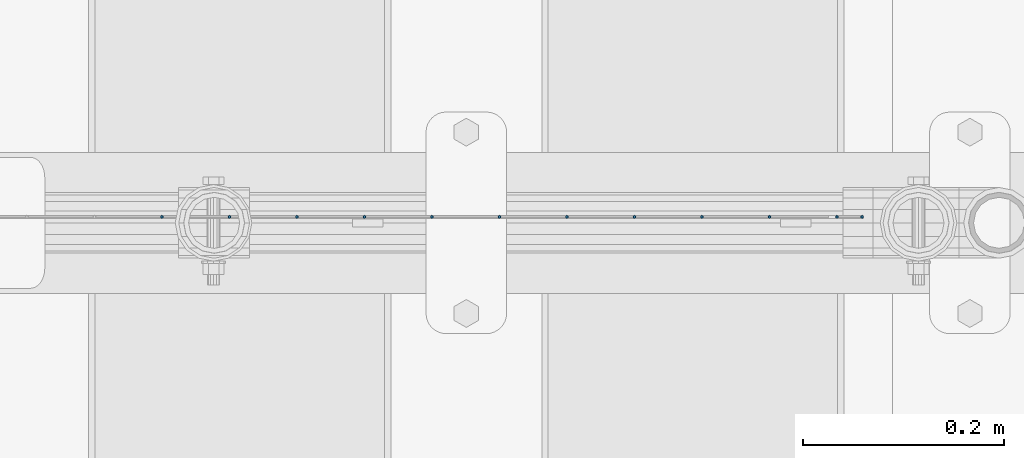
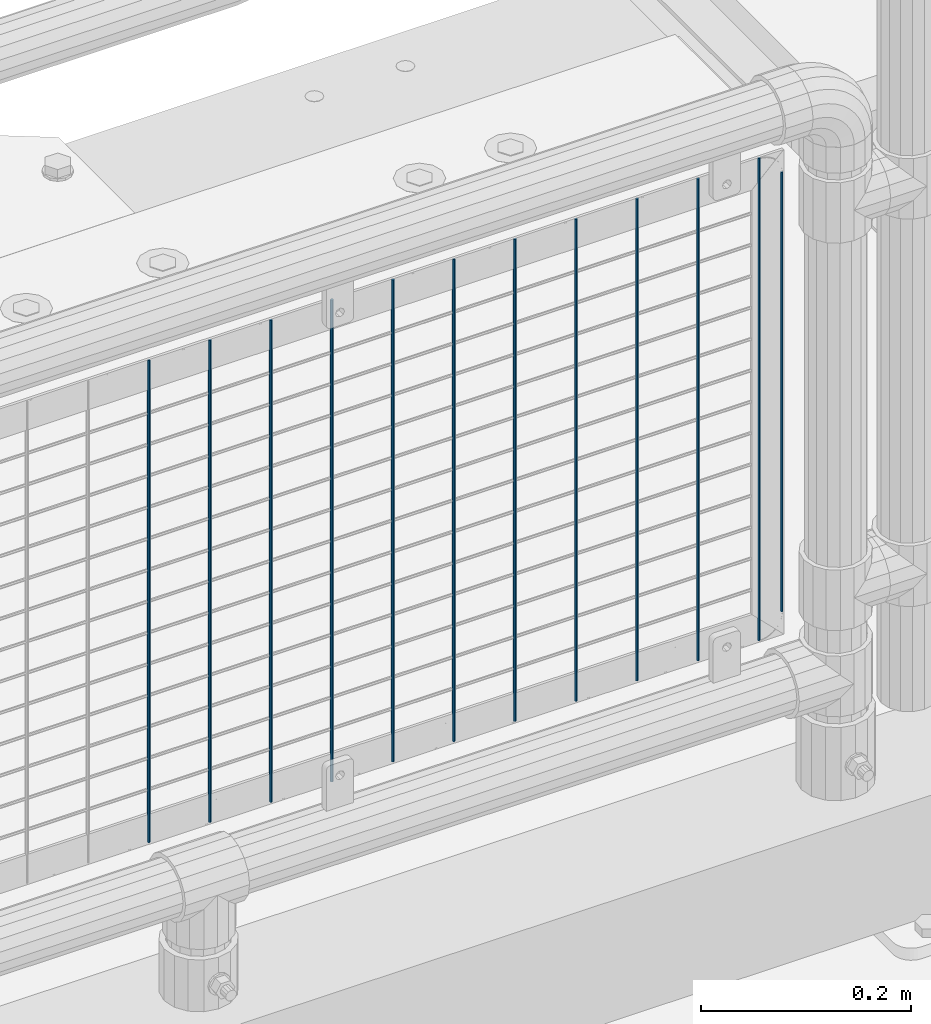
# One storey, part 112 of 270: 12 columns.
"""IFC2X3 building model written with IfcOpenShell, lengths in millimetres."""

from ifc_helpers import new_model, si_unit, frame, origin_with_axes, place, context, subcontext, project, spatial, faceted_brep, material, type_object, element, save


model = new_model("IFC2X3")

# Units and contexts
model_context = context("Model", 3, precision=1e-05, world=origin_with_axes())
body_context = subcontext(model_context, "Body", "Model", "MODEL_VIEW")
ifc_project = project(units=[si_unit("LENGTHUNIT", "METRE", prefix="MILLI"), si_unit("AREAUNIT", "SQUARE_METRE"), si_unit("VOLUMEUNIT", "CUBIC_METRE"), si_unit("MASSUNIT", "GRAM", prefix="KILO"), si_unit("TIMEUNIT", "SECOND"), si_unit("PLANEANGLEUNIT", "RADIAN"), si_unit("SOLIDANGLEUNIT", "STERADIAN"), si_unit("THERMODYNAMICTEMPERATUREUNIT", "DEGREE_CELSIUS"), si_unit("LUMINOUSINTENSITYUNIT", "LUMEN")], contexts=[model_context])

# Site, building, storey
site_placement = place(None, origin_with_axes())
site = spatial("IfcSite", under=ifc_project, at=site_placement, CompositionType="ELEMENT")
building_placement = place(site_placement, origin_with_axes())
building = spatial("IfcBuilding", under=site, at=building_placement, Name="Standard", CompositionType="ELEMENT")
storey_placement = place(building_placement, origin_with_axes())
storey = spatial("IfcBuildingStorey", under=building, at=storey_placement, Name="Undefined", CompositionType="ELEMENT", Elevation=0.0)

# Columns
ifc_material = material(Name="Misc_Undefined")
column_type = type_object("IfcColumnType", Name="D3", PredefinedType="NOTDEFINED")
for number, where, z_axis, x_axis in (
    (1, (19713.0020000001, -16329.5002158991, 353.02), (-1.0, 0.0, 0.0), (0.0, 0.0, 1.0)),
    (2, (19645.9740000001, -16329.5002016903, 353.02), (-1.0, 0.0, 0.0), (0.0, 0.0, 1.0)),
    (3, (19578.9460000001, -16329.5001874815, 353.02), (-1.0, 0.0, 0.0), (0.0, 0.0, 1.0)),
    (4, (19511.9180000001, -16329.5001732727, 353.02), (-1.0, 0.0, 0.0), (0.0, 0.0, 1.0)),
    (5, (19444.8900000001, -16329.5001590638, 353.02), (-1.0, 0.0, 0.0), (0.0, 0.0, 1.0)),
    (6, (19377.8620000001, -16329.500144855, 353.02), (-1.0, 0.0, 0.0), (0.0, 0.0, 1.0)),
    (7, (19310.8340000001, -16329.5001306462, 353.02), (-1.0, 0.0, 0.0), (0.0, 0.0, 1.0)),
    (8, (19109.7500000001, -16329.5000880198, 353.02), (-1.0, 0.0, 0.0), (0.0, 0.0, 1.0)),
    (9, (19042.7220000001, -16329.500073811, 353.02), (-1.0, 0.0, 0.0), (0.0, 0.0, 1.0)),
    (10, (19176.7780000001, -16329.5001022286, 353.02), (-1.0, 0.0, 0.0), (0.0, 0.0, 1.0)),
    (11, (19243.8060000001, -16329.5001164374, 353.02), (-1.0, 0.0, 0.0), (0.0, 0.0, 1.0)),
):
    element("IfcColumn", number, at=place(storey_placement, frame(where, z_axis=z_axis, x_axis=x_axis)), inside=storey, type_object=column_type, material=ifc_material, ObjectType="D3", context=body_context, shape_type="Brep", body=[
        faceted_brep([(0.0, -1.5, 0.0), (0.0, -0.75, -1.29903810567669), (560.0, -0.75, -1.29903810567703), (560.0, -1.5, 0.0), (0.0, 0.75, -1.29903810567669), (560.0, 0.75, -1.29903810567703), (0.0, 1.5, 0.0), (560.0, 1.5, 0.0), (0.0, 0.75, 1.29903810567669), (560.0, 0.75, 1.29903810567703), (0.0, -0.75, 1.29903810567669), (560.0, -0.75, 1.29903810567703)], [[[0, 1, 2, 3]], [[1, 4, 5, 2]], [[4, 6, 7, 5]], [[6, 8, 9, 7]], [[8, 10, 11, 9]], [[10, 0, 3, 11]], [[5, 7, 9, 11, 3, 2]], [[10, 8, 6, 4, 1, 0]]]),
    ])
column_placement = place(storey_placement, frame((19738.0000000001, -16329.5002211987, 378.02), z_axis=(-1.0, 0.0, 0.0), x_axis=(0.0, 0.0, 1.0)))
element("IfcColumn", 12, at=column_placement, inside=storey, type_object=column_type, material=ifc_material, ObjectType="D3", context=body_context, shape_type="Brep", body=[
    faceted_brep([(0.0, -1.5, 0.0), (0.0, -0.75, -1.29903810567669), (510.0, -0.75, -1.29903810567703), (510.0, -1.5, 0.0), (0.0, 0.75, -1.29903810567669), (510.0, 0.75, -1.29903810567703), (0.0, 1.5, 0.0), (510.0, 1.5, 0.0), (0.0, 0.75, 1.29903810567669), (510.0, 0.75, 1.29903810567703), (0.0, -0.75, 1.29903810567669), (510.0, -0.75, 1.29903810567703)], [[[0, 1, 2, 3]], [[1, 4, 5, 2]], [[4, 6, 7, 5]], [[6, 8, 9, 7]], [[8, 10, 11, 9]], [[10, 0, 3, 11]], [[5, 7, 9, 11, 3, 2]], [[10, 8, 6, 4, 1, 0]]]),
])

save(model, "model.ifc")
